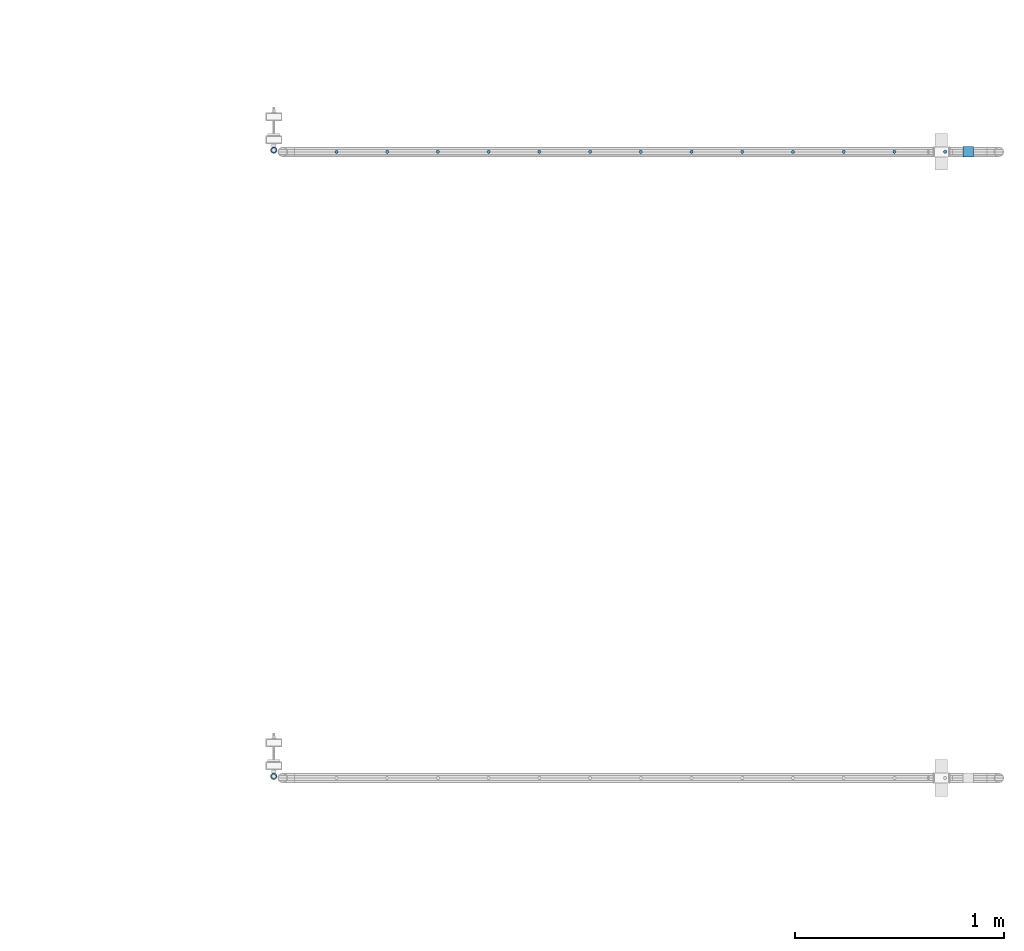
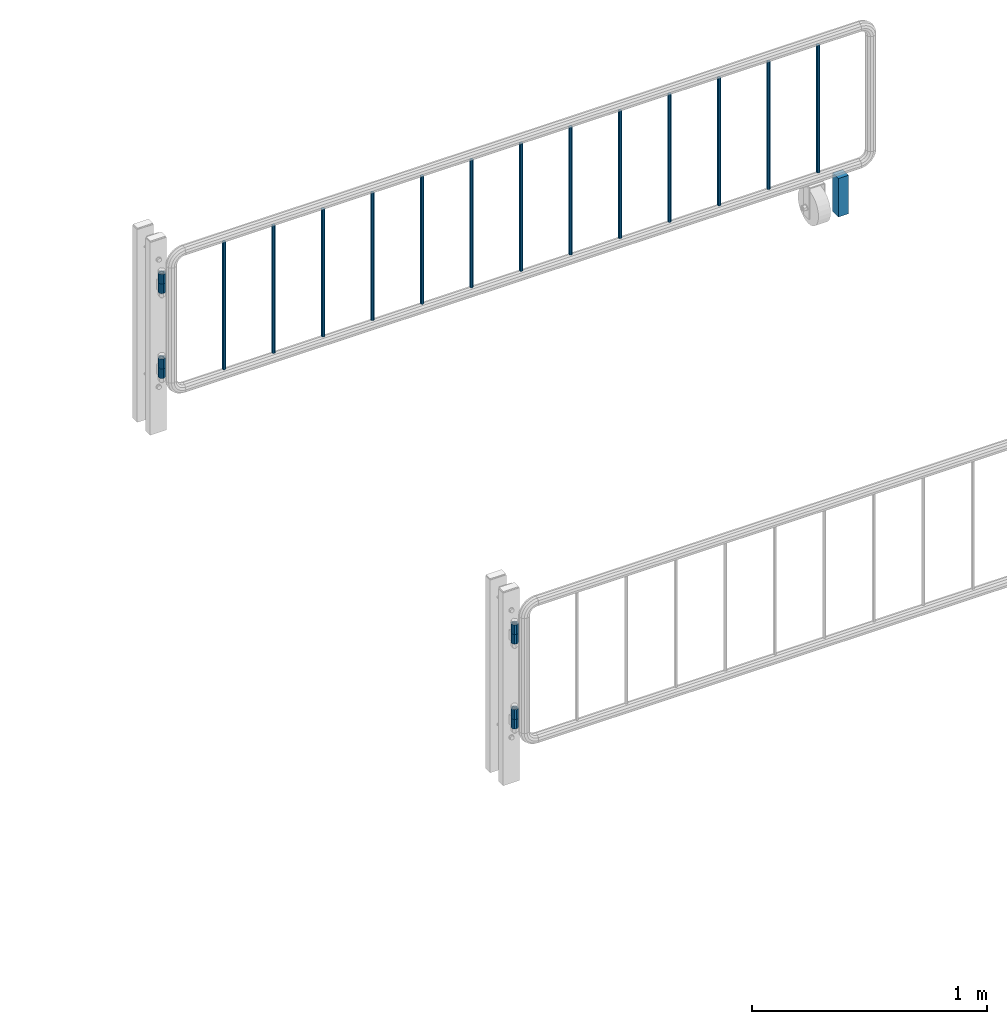
# One storey, part 106 of 247: 22 columns.
"""IFC2X3 building model written with IfcOpenShell, lengths in millimetres."""

from ifc_helpers import new_model, si_unit, frame, origin_with_axes, place, context, subcontext, project, spatial, faceted_brep, material, type_object, element, save


model = new_model("IFC2X3")

# Units and contexts
model_context = context("Model", 3, precision=1e-05, world=origin_with_axes())
body_context = subcontext(model_context, "Body", "Model", "MODEL_VIEW")
ifc_project = project(units=[si_unit("LENGTHUNIT", "METRE", prefix="MILLI"), si_unit("AREAUNIT", "SQUARE_METRE"), si_unit("VOLUMEUNIT", "CUBIC_METRE"), si_unit("MASSUNIT", "GRAM", prefix="KILO"), si_unit("TIMEUNIT", "SECOND"), si_unit("PLANEANGLEUNIT", "RADIAN"), si_unit("SOLIDANGLEUNIT", "STERADIAN"), si_unit("THERMODYNAMICTEMPERATUREUNIT", "DEGREE_CELSIUS"), si_unit("LUMINOUSINTENSITYUNIT", "LUMEN")], contexts=[model_context])

# Site, building, storey
site_placement = place(None, origin_with_axes())
site = spatial("IfcSite", under=ifc_project, at=site_placement, CompositionType="ELEMENT")
building_placement = place(site_placement, origin_with_axes())
building = spatial("IfcBuilding", under=site, at=building_placement, Name="Standard", CompositionType="ELEMENT")
storey_placement = place(building_placement, origin_with_axes())
storey = spatial("IfcBuildingStorey", under=building, at=storey_placement, Name="Undefined", CompositionType="ELEMENT", Elevation=0.0)

# Columns
ifc_material_1 = material(Name="STEEL/S355")
column_type_1 = type_object("IfcColumnType", PredefinedType="NOTDEFINED")
column_1_placement = place(storey_placement, frame((30182.0962679207, 8941.85337247848, 0.500000000007276), z_axis=(-1.0, 0.0, 0.0), x_axis=(0.0, 0.0, 1.0)))
element("IfcColumn", 1, at=column_1_placement, inside=storey, type_object=column_type_1, material=ifc_material_1, context=body_context, shape_type="Brep", body=[
    faceted_brep([(0.0, 25.0, -25.0), (0.0, 25.0, 25.0), (200.0, 25.0, 25.0), (200.0, 25.0, -25.0), (0.0, -25.0, 25.0), (200.0, -25.0, 25.0), (0.0, -25.0, -25.0), (200.0, -25.0, -25.0)], [[[0, 1, 2, 3]], [[1, 4, 5, 2]], [[4, 6, 7, 5]], [[6, 0, 3, 7]], [[5, 7, 3, 2]], [[6, 4, 1, 0]]]),
])
ifc_material_2 = material()
column_type_2 = type_object("IfcColumnType", PredefinedType="NOTDEFINED")
column_2_placement = place(storey_placement, frame((26855.7462679207, 5950.0033724785, 310.000000000008), z_axis=(-1.0, 0.0, 0.0), x_axis=(0.0, 0.0, 1.0)))
element("IfcColumn", 2, at=column_2_placement, inside=storey, type_object=column_type_2, material=ifc_material_2, context=body_context, shape_type="Brep", body=[
    faceted_brep([(-5.6843418860808e-14, -9.99999999999989, 3.5527136788005e-15), (0.0, -8.66025403784442, 5.0), (50.0, -8.66025403784442, 5.0), (50.0, -10.0, 0.0), (0.0, -5.0, 8.66025403784442), (50.0, -5.0, 8.66025403784442), (0.0, 0.0, 10.0), (50.0, 0.0, 10.0), (0.0, 5.0, 8.66025403784442), (50.0, 5.0, 8.66025403784442), (0.0, 8.66025403784442, 5.0), (50.0, 8.66025403784442, 5.0), (-5.6843418860808e-14, 10.0000000000001, 3.5527136788005e-15), (50.0, 10.0, 0.0), (0.0, 8.66025403784442, -5.0), (50.0, 8.66025403784442, -5.0), (0.0, 5.0, -8.66025403784442), (50.0, 5.0, -8.66025403784442), (-5.6843418860808e-14, 0.0, -10.0), (50.0, 0.0, -10.0), (0.0, -5.0, -8.66025403784442), (50.0, -5.0, -8.66025403784442), (0.0, -8.66025403784442, -5.0), (50.0, -8.66025403784442, -5.0), (0.0, -16.0, 0.0), (0.0, -13.8564064605507, -8.0), (50.0, -13.8564064605507, -8.0), (50.0, -16.0, 0.0), (0.0, -8.0, -13.8564064605525), (50.0, -8.0, -13.8564064605525), (4.95664914328755e-12, 0.0, -16.0), (50.0, 0.0, -16.0), (0.0, 8.0, -13.8564064605525), (50.0, 8.0, -13.8564064605525), (0.0, 13.8564064605507, -8.0), (50.0, 13.8564064605507, -8.0), (0.0, 16.0, 0.0), (50.0, 16.0, 0.0), (0.0, 13.8564064605507, 8.0), (50.0, 13.8564064605507, 8.0), (0.0, 8.0, 13.8564064605525), (50.0, 8.0, 13.8564064605525), (-1.65813757056052e-12, 0.0, 16.0), (50.0, 0.0, 16.0), (0.0, -8.0, 13.8564064605525), (50.0, -8.0, 13.8564064605525), (0.0, -13.8564064605507, 8.0), (50.0, -13.8564064605507, 8.0)], [[[0, 1, 2, 3]], [[1, 4, 5, 2]], [[4, 6, 7, 5]], [[6, 8, 9, 7]], [[8, 10, 11, 9]], [[10, 12, 13, 11]], [[12, 14, 15, 13]], [[14, 16, 17, 15]], [[16, 18, 19, 17]], [[18, 20, 21, 19]], [[20, 22, 23, 21]], [[22, 0, 3, 23]], [[24, 25, 26, 27]], [[25, 28, 29, 26]], [[28, 30, 31, 29]], [[30, 32, 33, 31]], [[32, 34, 35, 33]], [[34, 36, 37, 35]], [[36, 38, 39, 37]], [[38, 40, 41, 39]], [[40, 42, 43, 41]], [[42, 44, 45, 43]], [[44, 46, 47, 45]], [[46, 24, 27, 47]], [[29, 31, 33, 35, 37, 39, 41, 43, 45, 47, 27, 26], [5, 7, 9, 11, 13, 15, 17, 19, 21, 23, 3, 2]], [[46, 44, 42, 40, 38, 36, 34, 32, 30, 28, 25, 24], [22, 20, 18, 16, 14, 12, 10, 8, 6, 4, 1, 0]]]),
])
column_3_placement = place(storey_placement, frame((26855.7462679207, 5950.0033724785, 360.000000000008), z_axis=(-1.0, 0.0, 0.0), x_axis=(0.0, 0.0, 1.0)))
element("IfcColumn", 3, at=column_3_placement, inside=storey, type_object=column_type_2, material=ifc_material_2, context=body_context, shape_type="Brep", body=[
    faceted_brep([(-5.6843418860808e-14, -9.99999999999989, 3.5527136788005e-15), (0.0, -8.66025403784442, 5.0), (50.0, -8.66025403784442, 5.0), (50.0, -10.0, 0.0), (0.0, -5.0, 8.66025403784442), (50.0, -5.0, 8.66025403784442), (0.0, 0.0, 10.0), (50.0, 0.0, 10.0), (0.0, 5.0, 8.66025403784442), (50.0, 5.0, 8.66025403784442), (0.0, 8.66025403784442, 5.0), (50.0, 8.66025403784442, 5.0), (-5.6843418860808e-14, 10.0000000000001, 3.5527136788005e-15), (50.0, 10.0, 0.0), (0.0, 8.66025403784442, -5.0), (50.0, 8.66025403784442, -5.0), (0.0, 5.0, -8.66025403784442), (50.0, 5.0, -8.66025403784442), (-5.6843418860808e-14, 0.0, -10.0), (50.0, 0.0, -10.0), (0.0, -5.0, -8.66025403784442), (50.0, -5.0, -8.66025403784442), (0.0, -8.66025403784442, -5.0), (50.0, -8.66025403784442, -5.0), (0.0, -16.0, 0.0), (0.0, -13.8564064605507, -8.0), (50.0, -13.8564064605507, -8.0), (50.0, -16.0, 0.0), (0.0, -8.0, -13.8564064605525), (50.0, -8.0, -13.8564064605525), (4.95664914328755e-12, 0.0, -16.0), (50.0, 0.0, -16.0), (0.0, 8.0, -13.8564064605525), (50.0, 8.0, -13.8564064605525), (0.0, 13.8564064605507, -8.0), (50.0, 13.8564064605507, -8.0), (0.0, 16.0, 0.0), (50.0, 16.0, 0.0), (0.0, 13.8564064605507, 8.0), (50.0, 13.8564064605507, 8.0), (0.0, 8.0, 13.8564064605525), (50.0, 8.0, 13.8564064605525), (-1.65813757056052e-12, 0.0, 16.0), (50.0, 0.0, 16.0), (0.0, -8.0, 13.8564064605525), (50.0, -8.0, 13.8564064605525), (0.0, -13.8564064605507, 8.0), (50.0, -13.8564064605507, 8.0)], [[[0, 1, 2, 3]], [[1, 4, 5, 2]], [[4, 6, 7, 5]], [[6, 8, 9, 7]], [[8, 10, 11, 9]], [[10, 12, 13, 11]], [[12, 14, 15, 13]], [[14, 16, 17, 15]], [[16, 18, 19, 17]], [[18, 20, 21, 19]], [[20, 22, 23, 21]], [[22, 0, 3, 23]], [[24, 25, 26, 27]], [[25, 28, 29, 26]], [[28, 30, 31, 29]], [[30, 32, 33, 31]], [[32, 34, 35, 33]], [[34, 36, 37, 35]], [[36, 38, 39, 37]], [[38, 40, 41, 39]], [[40, 42, 43, 41]], [[42, 44, 45, 43]], [[44, 46, 47, 45]], [[46, 24, 27, 47]], [[29, 31, 33, 35, 37, 39, 41, 43, 45, 47, 27, 26], [5, 7, 9, 11, 13, 15, 17, 19, 21, 23, 3, 2]], [[46, 44, 42, 40, 38, 36, 34, 32, 30, 28, 25, 24], [22, 20, 18, 16, 14, 12, 10, 8, 6, 4, 1, 0]]]),
])
column_4_placement = place(storey_placement, frame((26855.7462679207, 5950.0033724785, 750.000000000008), z_axis=(-1.0, 0.0, 0.0), x_axis=(0.0, 0.0, 1.0)))
element("IfcColumn", 4, at=column_4_placement, inside=storey, type_object=column_type_2, material=ifc_material_2, context=body_context, shape_type="Brep", body=[
    faceted_brep([(-5.6843418860808e-14, -9.99999999999989, 3.5527136788005e-15), (0.0, -8.66025403784442, 5.0), (50.0, -8.66025403784442, 5.0), (50.0, -10.0, 0.0), (0.0, -5.0, 8.66025403784442), (50.0, -5.0, 8.66025403784442), (0.0, 0.0, 10.0), (50.0, 0.0, 10.0), (0.0, 5.0, 8.66025403784442), (50.0, 5.0, 8.66025403784442), (0.0, 8.66025403784442, 5.0), (50.0, 8.66025403784442, 5.0), (-5.6843418860808e-14, 10.0000000000001, 3.5527136788005e-15), (50.0, 10.0, 0.0), (0.0, 8.66025403784442, -5.0), (50.0, 8.66025403784442, -5.0), (0.0, 5.0, -8.66025403784442), (50.0, 5.0, -8.66025403784442), (-5.6843418860808e-14, 0.0, -10.0), (50.0, 0.0, -10.0), (0.0, -5.0, -8.66025403784442), (50.0, -5.0, -8.66025403784442), (0.0, -8.66025403784442, -5.0), (50.0, -8.66025403784442, -5.0), (0.0, -16.0, 0.0), (0.0, -13.8564064605507, -8.0), (50.0, -13.8564064605507, -8.0), (50.0, -16.0, 0.0), (0.0, -8.0, -13.8564064605525), (50.0, -8.0, -13.8564064605525), (4.95664914328755e-12, 0.0, -16.0), (50.0, 0.0, -16.0), (0.0, 8.0, -13.8564064605525), (50.0, 8.0, -13.8564064605525), (0.0, 13.8564064605507, -8.0), (50.0, 13.8564064605507, -8.0), (0.0, 16.0, 0.0), (50.0, 16.0, 0.0), (0.0, 13.8564064605507, 8.0), (50.0, 13.8564064605507, 8.0), (0.0, 8.0, 13.8564064605525), (50.0, 8.0, 13.8564064605525), (-1.65813757056052e-12, 0.0, 16.0), (50.0, 0.0, 16.0), (0.0, -8.0, 13.8564064605525), (50.0, -8.0, 13.8564064605525), (0.0, -13.8564064605507, 8.0), (50.0, -13.8564064605507, 8.0)], [[[0, 1, 2, 3]], [[1, 4, 5, 2]], [[4, 6, 7, 5]], [[6, 8, 9, 7]], [[8, 10, 11, 9]], [[10, 12, 13, 11]], [[12, 14, 15, 13]], [[14, 16, 17, 15]], [[16, 18, 19, 17]], [[18, 20, 21, 19]], [[20, 22, 23, 21]], [[22, 0, 3, 23]], [[24, 25, 26, 27]], [[25, 28, 29, 26]], [[28, 30, 31, 29]], [[30, 32, 33, 31]], [[32, 34, 35, 33]], [[34, 36, 37, 35]], [[36, 38, 39, 37]], [[38, 40, 41, 39]], [[40, 42, 43, 41]], [[42, 44, 45, 43]], [[44, 46, 47, 45]], [[46, 24, 27, 47]], [[29, 31, 33, 35, 37, 39, 41, 43, 45, 47, 27, 26], [5, 7, 9, 11, 13, 15, 17, 19, 21, 23, 3, 2]], [[46, 44, 42, 40, 38, 36, 34, 32, 30, 28, 25, 24], [22, 20, 18, 16, 14, 12, 10, 8, 6, 4, 1, 0]]]),
])
column_5_placement = place(storey_placement, frame((26855.7462679207, 5950.0033724785, 800.000000000008), z_axis=(-1.0, 0.0, 0.0), x_axis=(0.0, 0.0, 1.0)))
element("IfcColumn", 5, at=column_5_placement, inside=storey, type_object=column_type_2, material=ifc_material_2, context=body_context, shape_type="Brep", body=[
    faceted_brep([(-5.6843418860808e-14, -9.99999999999989, 3.5527136788005e-15), (0.0, -8.66025403784442, 5.0), (50.0, -8.66025403784442, 5.0), (50.0, -10.0, 0.0), (0.0, -5.0, 8.66025403784442), (50.0, -5.0, 8.66025403784442), (0.0, 0.0, 10.0), (50.0, 0.0, 10.0), (0.0, 5.0, 8.66025403784442), (50.0, 5.0, 8.66025403784442), (0.0, 8.66025403784442, 5.0), (50.0, 8.66025403784442, 5.0), (-5.6843418860808e-14, 10.0000000000001, 3.5527136788005e-15), (50.0, 10.0, 0.0), (0.0, 8.66025403784442, -5.0), (50.0, 8.66025403784442, -5.0), (0.0, 5.0, -8.66025403784442), (50.0, 5.0, -8.66025403784442), (-5.6843418860808e-14, 0.0, -10.0), (50.0, 0.0, -10.0), (0.0, -5.0, -8.66025403784442), (50.0, -5.0, -8.66025403784442), (0.0, -8.66025403784442, -5.0), (50.0, -8.66025403784442, -5.0), (0.0, -16.0, 0.0), (0.0, -13.8564064605507, -8.0), (50.0, -13.8564064605507, -8.0), (50.0, -16.0, 0.0), (0.0, -8.0, -13.8564064605525), (50.0, -8.0, -13.8564064605525), (4.95664914328755e-12, 0.0, -16.0), (50.0, 0.0, -16.0), (0.0, 8.0, -13.8564064605525), (50.0, 8.0, -13.8564064605525), (0.0, 13.8564064605507, -8.0), (50.0, 13.8564064605507, -8.0), (0.0, 16.0, 0.0), (50.0, 16.0, 0.0), (0.0, 13.8564064605507, 8.0), (50.0, 13.8564064605507, 8.0), (0.0, 8.0, 13.8564064605525), (50.0, 8.0, 13.8564064605525), (-1.65813757056052e-12, 0.0, 16.0), (50.0, 0.0, 16.0), (0.0, -8.0, 13.8564064605525), (50.0, -8.0, 13.8564064605525), (0.0, -13.8564064605507, 8.0), (50.0, -13.8564064605507, 8.0)], [[[0, 1, 2, 3]], [[1, 4, 5, 2]], [[4, 6, 7, 5]], [[6, 8, 9, 7]], [[8, 10, 11, 9]], [[10, 12, 13, 11]], [[12, 14, 15, 13]], [[14, 16, 17, 15]], [[16, 18, 19, 17]], [[18, 20, 21, 19]], [[20, 22, 23, 21]], [[22, 0, 3, 23]], [[24, 25, 26, 27]], [[25, 28, 29, 26]], [[28, 30, 31, 29]], [[30, 32, 33, 31]], [[32, 34, 35, 33]], [[34, 36, 37, 35]], [[36, 38, 39, 37]], [[38, 40, 41, 39]], [[40, 42, 43, 41]], [[42, 44, 45, 43]], [[44, 46, 47, 45]], [[46, 24, 27, 47]], [[29, 31, 33, 35, 37, 39, 41, 43, 45, 47, 27, 26], [5, 7, 9, 11, 13, 15, 17, 19, 21, 23, 3, 2]], [[46, 44, 42, 40, 38, 36, 34, 32, 30, 28, 25, 24], [22, 20, 18, 16, 14, 12, 10, 8, 6, 4, 1, 0]]]),
])
column_6_placement = place(storey_placement, frame((26855.7462679207, 8950.0033724785, 310.000000000008), z_axis=(-1.0, 0.0, 0.0), x_axis=(0.0, 0.0, 1.0)))
element("IfcColumn", 6, at=column_6_placement, inside=storey, type_object=column_type_2, material=ifc_material_2, context=body_context, shape_type="Brep", body=[
    faceted_brep([(-5.6843418860808e-14, -9.99999999999989, 3.5527136788005e-15), (0.0, -8.66025403784442, 5.0), (50.0, -8.66025403784442, 5.0), (50.0, -10.0, 0.0), (0.0, -5.0, 8.66025403784442), (50.0, -5.0, 8.66025403784442), (0.0, 0.0, 10.0), (50.0, 0.0, 10.0), (0.0, 5.0, 8.66025403784442), (50.0, 5.0, 8.66025403784442), (0.0, 8.66025403784442, 5.0), (50.0, 8.66025403784442, 5.0), (-5.6843418860808e-14, 10.0000000000001, 3.5527136788005e-15), (50.0, 10.0, 0.0), (0.0, 8.66025403784442, -5.0), (50.0, 8.66025403784442, -5.0), (0.0, 5.0, -8.66025403784442), (50.0, 5.0, -8.66025403784442), (-5.6843418860808e-14, 0.0, -10.0), (50.0, 0.0, -10.0), (0.0, -5.0, -8.66025403784442), (50.0, -5.0, -8.66025403784442), (0.0, -8.66025403784442, -5.0), (50.0, -8.66025403784442, -5.0), (0.0, -16.0, 0.0), (0.0, -13.8564064605507, -8.0), (50.0, -13.8564064605507, -8.0), (50.0, -16.0, 0.0), (0.0, -8.0, -13.8564064605525), (50.0, -8.0, -13.8564064605525), (4.95664914328755e-12, 0.0, -16.0), (50.0, 0.0, -16.0), (0.0, 8.0, -13.8564064605525), (50.0, 8.0, -13.8564064605525), (0.0, 13.8564064605507, -8.0), (50.0, 13.8564064605507, -8.0), (0.0, 16.0, 0.0), (50.0, 16.0, 0.0), (0.0, 13.8564064605507, 8.0), (50.0, 13.8564064605507, 8.0), (0.0, 8.0, 13.8564064605525), (50.0, 8.0, 13.8564064605525), (-1.65813757056052e-12, 0.0, 16.0), (50.0, 0.0, 16.0), (0.0, -8.0, 13.8564064605525), (50.0, -8.0, 13.8564064605525), (0.0, -13.8564064605507, 8.0), (50.0, -13.8564064605507, 8.0)], [[[0, 1, 2, 3]], [[1, 4, 5, 2]], [[4, 6, 7, 5]], [[6, 8, 9, 7]], [[8, 10, 11, 9]], [[10, 12, 13, 11]], [[12, 14, 15, 13]], [[14, 16, 17, 15]], [[16, 18, 19, 17]], [[18, 20, 21, 19]], [[20, 22, 23, 21]], [[22, 0, 3, 23]], [[24, 25, 26, 27]], [[25, 28, 29, 26]], [[28, 30, 31, 29]], [[30, 32, 33, 31]], [[32, 34, 35, 33]], [[34, 36, 37, 35]], [[36, 38, 39, 37]], [[38, 40, 41, 39]], [[40, 42, 43, 41]], [[42, 44, 45, 43]], [[44, 46, 47, 45]], [[46, 24, 27, 47]], [[29, 31, 33, 35, 37, 39, 41, 43, 45, 47, 27, 26], [5, 7, 9, 11, 13, 15, 17, 19, 21, 23, 3, 2]], [[46, 44, 42, 40, 38, 36, 34, 32, 30, 28, 25, 24], [22, 20, 18, 16, 14, 12, 10, 8, 6, 4, 1, 0]]]),
])
column_7_placement = place(storey_placement, frame((26855.7462679207, 8950.0033724785, 360.000000000008), z_axis=(-1.0, 0.0, 0.0), x_axis=(0.0, 0.0, 1.0)))
element("IfcColumn", 7, at=column_7_placement, inside=storey, type_object=column_type_2, material=ifc_material_2, context=body_context, shape_type="Brep", body=[
    faceted_brep([(-5.6843418860808e-14, -9.99999999999989, 3.5527136788005e-15), (0.0, -8.66025403784442, 5.0), (50.0, -8.66025403784442, 5.0), (50.0, -10.0, 0.0), (0.0, -5.0, 8.66025403784442), (50.0, -5.0, 8.66025403784442), (0.0, 0.0, 10.0), (50.0, 0.0, 10.0), (0.0, 5.0, 8.66025403784442), (50.0, 5.0, 8.66025403784442), (0.0, 8.66025403784442, 5.0), (50.0, 8.66025403784442, 5.0), (-5.6843418860808e-14, 10.0000000000001, 3.5527136788005e-15), (50.0, 10.0, 0.0), (0.0, 8.66025403784442, -5.0), (50.0, 8.66025403784442, -5.0), (0.0, 5.0, -8.66025403784442), (50.0, 5.0, -8.66025403784442), (-5.6843418860808e-14, 0.0, -10.0), (50.0, 0.0, -10.0), (0.0, -5.0, -8.66025403784442), (50.0, -5.0, -8.66025403784442), (0.0, -8.66025403784442, -5.0), (50.0, -8.66025403784442, -5.0), (0.0, -16.0, 0.0), (0.0, -13.8564064605507, -8.0), (50.0, -13.8564064605507, -8.0), (50.0, -16.0, 0.0), (0.0, -8.0, -13.8564064605525), (50.0, -8.0, -13.8564064605525), (4.95664914328755e-12, 0.0, -16.0), (50.0, 0.0, -16.0), (0.0, 8.0, -13.8564064605525), (50.0, 8.0, -13.8564064605525), (0.0, 13.8564064605507, -8.0), (50.0, 13.8564064605507, -8.0), (0.0, 16.0, 0.0), (50.0, 16.0, 0.0), (0.0, 13.8564064605507, 8.0), (50.0, 13.8564064605507, 8.0), (0.0, 8.0, 13.8564064605525), (50.0, 8.0, 13.8564064605525), (-1.65813757056052e-12, 0.0, 16.0), (50.0, 0.0, 16.0), (0.0, -8.0, 13.8564064605525), (50.0, -8.0, 13.8564064605525), (0.0, -13.8564064605507, 8.0), (50.0, -13.8564064605507, 8.0)], [[[0, 1, 2, 3]], [[1, 4, 5, 2]], [[4, 6, 7, 5]], [[6, 8, 9, 7]], [[8, 10, 11, 9]], [[10, 12, 13, 11]], [[12, 14, 15, 13]], [[14, 16, 17, 15]], [[16, 18, 19, 17]], [[18, 20, 21, 19]], [[20, 22, 23, 21]], [[22, 0, 3, 23]], [[24, 25, 26, 27]], [[25, 28, 29, 26]], [[28, 30, 31, 29]], [[30, 32, 33, 31]], [[32, 34, 35, 33]], [[34, 36, 37, 35]], [[36, 38, 39, 37]], [[38, 40, 41, 39]], [[40, 42, 43, 41]], [[42, 44, 45, 43]], [[44, 46, 47, 45]], [[46, 24, 27, 47]], [[29, 31, 33, 35, 37, 39, 41, 43, 45, 47, 27, 26], [5, 7, 9, 11, 13, 15, 17, 19, 21, 23, 3, 2]], [[46, 44, 42, 40, 38, 36, 34, 32, 30, 28, 25, 24], [22, 20, 18, 16, 14, 12, 10, 8, 6, 4, 1, 0]]]),
])
column_8_placement = place(storey_placement, frame((26855.7462679207, 8950.0033724785, 750.000000000008), z_axis=(-1.0, 0.0, 0.0), x_axis=(0.0, 0.0, 1.0)))
element("IfcColumn", 8, at=column_8_placement, inside=storey, type_object=column_type_2, material=ifc_material_2, context=body_context, shape_type="Brep", body=[
    faceted_brep([(-5.6843418860808e-14, -9.99999999999989, 3.5527136788005e-15), (0.0, -8.66025403784442, 5.0), (50.0, -8.66025403784442, 5.0), (50.0, -10.0, 0.0), (0.0, -5.0, 8.66025403784442), (50.0, -5.0, 8.66025403784442), (0.0, 0.0, 10.0), (50.0, 0.0, 10.0), (0.0, 5.0, 8.66025403784442), (50.0, 5.0, 8.66025403784442), (0.0, 8.66025403784442, 5.0), (50.0, 8.66025403784442, 5.0), (-5.6843418860808e-14, 10.0000000000001, 3.5527136788005e-15), (50.0, 10.0, 0.0), (0.0, 8.66025403784442, -5.0), (50.0, 8.66025403784442, -5.0), (0.0, 5.0, -8.66025403784442), (50.0, 5.0, -8.66025403784442), (-5.6843418860808e-14, 0.0, -10.0), (50.0, 0.0, -10.0), (0.0, -5.0, -8.66025403784442), (50.0, -5.0, -8.66025403784442), (0.0, -8.66025403784442, -5.0), (50.0, -8.66025403784442, -5.0), (0.0, -16.0, 0.0), (0.0, -13.8564064605507, -8.0), (50.0, -13.8564064605507, -8.0), (50.0, -16.0, 0.0), (0.0, -8.0, -13.8564064605525), (50.0, -8.0, -13.8564064605525), (4.95664914328755e-12, 0.0, -16.0), (50.0, 0.0, -16.0), (0.0, 8.0, -13.8564064605525), (50.0, 8.0, -13.8564064605525), (0.0, 13.8564064605507, -8.0), (50.0, 13.8564064605507, -8.0), (0.0, 16.0, 0.0), (50.0, 16.0, 0.0), (0.0, 13.8564064605507, 8.0), (50.0, 13.8564064605507, 8.0), (0.0, 8.0, 13.8564064605525), (50.0, 8.0, 13.8564064605525), (-1.65813757056052e-12, 0.0, 16.0), (50.0, 0.0, 16.0), (0.0, -8.0, 13.8564064605525), (50.0, -8.0, 13.8564064605525), (0.0, -13.8564064605507, 8.0), (50.0, -13.8564064605507, 8.0)], [[[0, 1, 2, 3]], [[1, 4, 5, 2]], [[4, 6, 7, 5]], [[6, 8, 9, 7]], [[8, 10, 11, 9]], [[10, 12, 13, 11]], [[12, 14, 15, 13]], [[14, 16, 17, 15]], [[16, 18, 19, 17]], [[18, 20, 21, 19]], [[20, 22, 23, 21]], [[22, 0, 3, 23]], [[24, 25, 26, 27]], [[25, 28, 29, 26]], [[28, 30, 31, 29]], [[30, 32, 33, 31]], [[32, 34, 35, 33]], [[34, 36, 37, 35]], [[36, 38, 39, 37]], [[38, 40, 41, 39]], [[40, 42, 43, 41]], [[42, 44, 45, 43]], [[44, 46, 47, 45]], [[46, 24, 27, 47]], [[29, 31, 33, 35, 37, 39, 41, 43, 45, 47, 27, 26], [5, 7, 9, 11, 13, 15, 17, 19, 21, 23, 3, 2]], [[46, 44, 42, 40, 38, 36, 34, 32, 30, 28, 25, 24], [22, 20, 18, 16, 14, 12, 10, 8, 6, 4, 1, 0]]]),
])
column_9_placement = place(storey_placement, frame((26855.7462679207, 8950.0033724785, 800.000000000008), z_axis=(-1.0, 0.0, 0.0), x_axis=(0.0, 0.0, 1.0)))
element("IfcColumn", 9, at=column_9_placement, inside=storey, type_object=column_type_2, material=ifc_material_2, context=body_context, shape_type="Brep", body=[
    faceted_brep([(-5.6843418860808e-14, -9.99999999999989, 3.5527136788005e-15), (0.0, -8.66025403784442, 5.0), (50.0, -8.66025403784442, 5.0), (50.0, -10.0, 0.0), (0.0, -5.0, 8.66025403784442), (50.0, -5.0, 8.66025403784442), (0.0, 0.0, 10.0), (50.0, 0.0, 10.0), (0.0, 5.0, 8.66025403784442), (50.0, 5.0, 8.66025403784442), (0.0, 8.66025403784442, 5.0), (50.0, 8.66025403784442, 5.0), (-5.6843418860808e-14, 10.0000000000001, 3.5527136788005e-15), (50.0, 10.0, 0.0), (0.0, 8.66025403784442, -5.0), (50.0, 8.66025403784442, -5.0), (0.0, 5.0, -8.66025403784442), (50.0, 5.0, -8.66025403784442), (-5.6843418860808e-14, 0.0, -10.0), (50.0, 0.0, -10.0), (0.0, -5.0, -8.66025403784442), (50.0, -5.0, -8.66025403784442), (0.0, -8.66025403784442, -5.0), (50.0, -8.66025403784442, -5.0), (0.0, -16.0, 0.0), (0.0, -13.8564064605507, -8.0), (50.0, -13.8564064605507, -8.0), (50.0, -16.0, 0.0), (0.0, -8.0, -13.8564064605525), (50.0, -8.0, -13.8564064605525), (4.95664914328755e-12, 0.0, -16.0), (50.0, 0.0, -16.0), (0.0, 8.0, -13.8564064605525), (50.0, 8.0, -13.8564064605525), (0.0, 13.8564064605507, -8.0), (50.0, 13.8564064605507, -8.0), (0.0, 16.0, 0.0), (50.0, 16.0, 0.0), (0.0, 13.8564064605507, 8.0), (50.0, 13.8564064605507, 8.0), (0.0, 8.0, 13.8564064605525), (50.0, 8.0, 13.8564064605525), (-1.65813757056052e-12, 0.0, 16.0), (50.0, 0.0, 16.0), (0.0, -8.0, 13.8564064605525), (50.0, -8.0, 13.8564064605525), (0.0, -13.8564064605507, 8.0), (50.0, -13.8564064605507, 8.0)], [[[0, 1, 2, 3]], [[1, 4, 5, 2]], [[4, 6, 7, 5]], [[6, 8, 9, 7]], [[8, 10, 11, 9]], [[10, 12, 13, 11]], [[12, 14, 15, 13]], [[14, 16, 17, 15]], [[16, 18, 19, 17]], [[18, 20, 21, 19]], [[20, 22, 23, 21]], [[22, 0, 3, 23]], [[24, 25, 26, 27]], [[25, 28, 29, 26]], [[28, 30, 31, 29]], [[30, 32, 33, 31]], [[32, 34, 35, 33]], [[34, 36, 37, 35]], [[36, 38, 39, 37]], [[38, 40, 41, 39]], [[40, 42, 43, 41]], [[42, 44, 45, 43]], [[44, 46, 47, 45]], [[46, 24, 27, 47]], [[29, 31, 33, 35, 37, 39, 41, 43, 45, 47, 27, 26], [5, 7, 9, 11, 13, 15, 17, 19, 21, 23, 3, 2]], [[46, 44, 42, 40, 38, 36, 34, 32, 30, 28, 25, 24], [22, 20, 18, 16, 14, 12, 10, 8, 6, 4, 1, 0]]]),
])
ifc_material_3 = material(Name="STEEL/S355J2")
column_type_3 = type_object("IfcColumnType", Name="D16", PredefinedType="NOTDEFINED")
for number, where, z_axis, x_axis in (
    (10, (27156.0962679207, 8941.85337247848, 248.800000000007), (-1.0, 0.0, 0.0), (0.0, 0.0, 1.0)),
    (11, (27399.0962679207, 8941.85337247848, 248.800000000007), (-1.0, 0.0, 0.0), (0.0, 0.0, 1.0)),
    (12, (27642.0962679207, 8941.85337247848, 248.800000000007), (-1.0, 0.0, 0.0), (0.0, 0.0, 1.0)),
    (13, (27885.0962679207, 8941.85337247848, 248.800000000007), (-1.0, 0.0, 0.0), (0.0, 0.0, 1.0)),
    (14, (28128.0962679207, 8941.85337247848, 248.800000000007), (-1.0, 0.0, 0.0), (0.0, 0.0, 1.0)),
    (15, (28371.0962679207, 8941.85337247848, 248.800000000007), (-1.0, 0.0, 0.0), (0.0, 0.0, 1.0)),
    (16, (28614.0962679207, 8941.85337247848, 248.800000000007), (-1.0, 0.0, 0.0), (0.0, 0.0, 1.0)),
    (17, (28857.0962679207, 8941.85337247848, 248.800000000007), (-1.0, 0.0, 0.0), (0.0, 0.0, 1.0)),
    (18, (29100.0962679207, 8941.85337247848, 248.800000000007), (-1.0, 0.0, 0.0), (0.0, 0.0, 1.0)),
    (19, (29343.0962679207, 8941.85337247848, 248.800000000007), (-1.0, 0.0, 0.0), (0.0, 0.0, 1.0)),
    (20, (29586.0962679207, 8941.85337247848, 248.800000000007), (-1.0, 0.0, 0.0), (0.0, 0.0, 1.0)),
    (21, (29829.0962679207, 8941.85337247848, 248.800000000007), (-1.0, 0.0, 0.0), (0.0, 0.0, 1.0)),
    (22, (30072.0962679207, 8941.85337247848, 248.800000000007), (-1.0, 0.0, 0.0), (0.0, 0.0, 1.0)),
):
    element("IfcColumn", number, at=place(storey_placement, frame(where, z_axis=z_axis, x_axis=x_axis)), inside=storey, type_object=column_type_3, material=ifc_material_3, ObjectType="D16", context=body_context, shape_type="Brep", body=[
        faceted_brep([(0.0, -8.0, 0.0), (0.0, -5.65685424949243, -5.65685424949334), (663.0, -5.65685424949243, -5.65685424949334), (663.0, -8.0, 0.0), (2.47832457164377e-12, -4.54747350886464e-13, -8.0), (663.0, 0.0, -8.0), (0.0, 5.65685424949243, -5.65685424949334), (663.0, 5.65685424949243, -5.65685424949334), (0.0, 8.0, 0.0), (663.0, 8.0, 0.0), (0.0, 5.65685424949243, 5.65685424949334), (663.0, 5.65685424949243, 5.65685424949334), (-8.29068785280258e-13, -4.54747350886464e-13, 8.0), (663.0, 0.0, 8.0), (0.0, -5.65685424949243, 5.65685424949334), (663.0, -5.65685424949243, 5.65685424949334)], [[[0, 1, 2, 3]], [[1, 4, 5, 2]], [[4, 6, 7, 5]], [[6, 8, 9, 7]], [[8, 10, 11, 9]], [[10, 12, 13, 11]], [[12, 14, 15, 13]], [[14, 0, 3, 15]], [[5, 7, 9, 11, 13, 15, 3, 2]], [[14, 12, 10, 8, 6, 4, 1, 0]]]),
    ])

save(model, "model.ifc")
